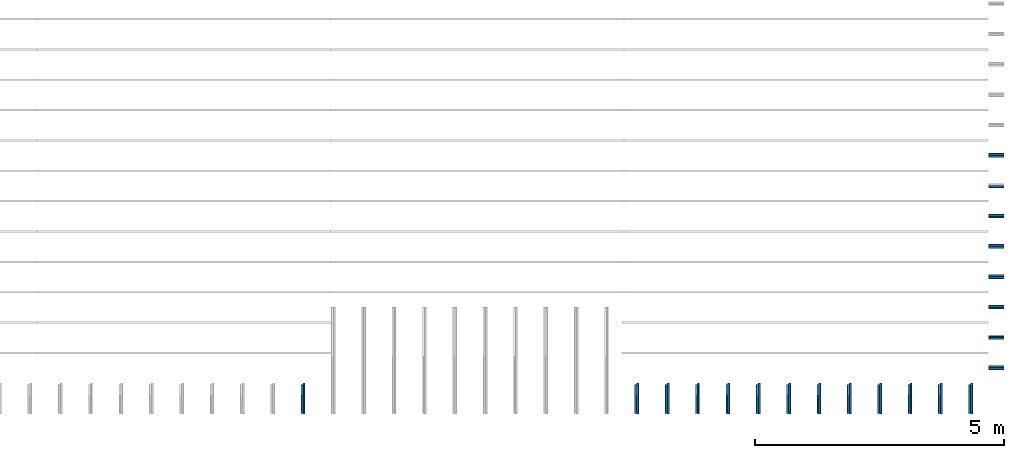
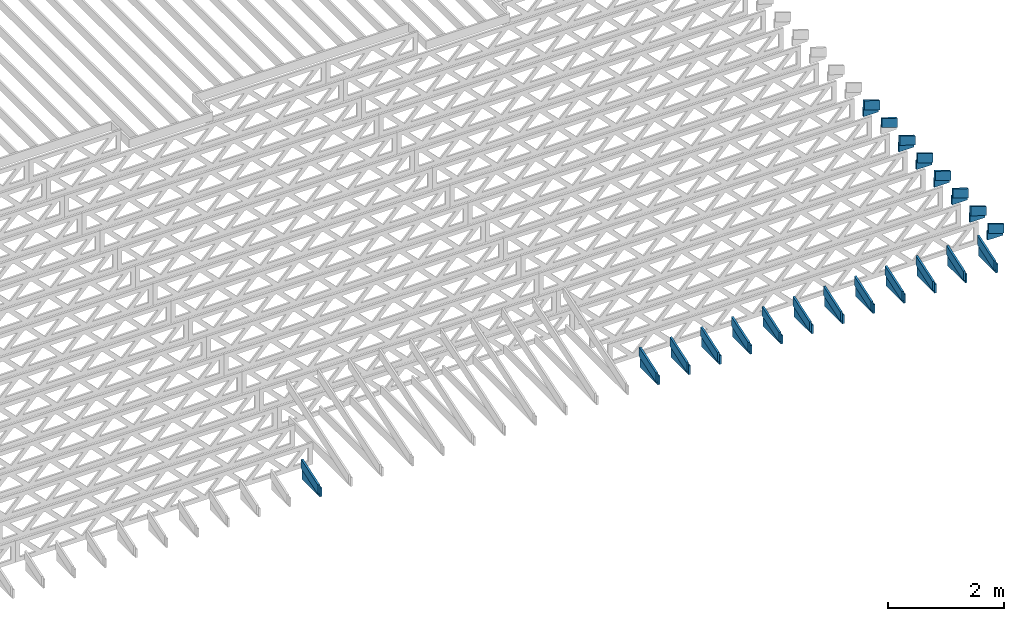
# One storey, part 15 of 17: 41 beams, 4 elements without a shape of their own.
"""IFC4 building model written with IfcOpenShell, lengths in feet."""

from ifc_helpers import new_model, entity, si_unit, converted_unit, derived_unit, direction, frame, frame_2d, origin, origin_2d_with_axis, place, context, subcontext, project, spatial, rectangle, extrude, clip, halfspace, source, transform, mapped, material, material_profile, profile_set, profile_usage, type_object, type_shapes, element, aggregate, save


model = new_model("IFC4")

# Units and contexts
model_context = context("Model", 3, precision=0.0001, world=origin(), true_north=direction((6.12303176911189e-17, 1.0)))
body_context = subcontext(model_context, "Body", "Model", "MODEL_VIEW")
ifc_project = project(units=[converted_unit("LENGTHUNIT", "FOOT", entity("IfcRatioMeasure", 0.3048), si_unit("LENGTHUNIT", "METRE"), dimensions=[1, 0, 0, 0, 0, 0, 0]), converted_unit("AREAUNIT", "SQUARE FOOT", entity("IfcRatioMeasure", 0.09290304), si_unit("AREAUNIT", "SQUARE_METRE"), dimensions=[2, 0, 0, 0, 0, 0, 0]), converted_unit("VOLUMEUNIT", "CUBIC FOOT", entity("IfcRatioMeasure", 0.028316846592), si_unit("VOLUMEUNIT", "CUBIC_METRE"), dimensions=[3, 0, 0, 0, 0, 0, 0]), converted_unit("PLANEANGLEUNIT", "DEGREE", entity("IfcRatioMeasure", 0.0174532925199433), si_unit("PLANEANGLEUNIT", "RADIAN"), dimensions=[0, 0, 0, 0, 0, 0, 0]), si_unit("MASSUNIT", "GRAM", prefix="KILO"), derived_unit("MASSDENSITYUNIT", [(si_unit("MASSUNIT", "GRAM", prefix="KILO"), 1), (si_unit("LENGTHUNIT", "METRE"), -3)]), derived_unit("MOMENTOFINERTIAUNIT", [(si_unit("LENGTHUNIT", "METRE"), 4)]), si_unit("TIMEUNIT", "SECOND"), si_unit("FREQUENCYUNIT", "HERTZ"), si_unit("THERMODYNAMICTEMPERATUREUNIT", "DEGREE_CELSIUS"), derived_unit("THERMALTRANSMITTANCEUNIT", [(si_unit("MASSUNIT", "GRAM", prefix="KILO"), 1), (si_unit("THERMODYNAMICTEMPERATUREUNIT", "KELVIN"), -1), (si_unit("TIMEUNIT", "SECOND"), -3)]), derived_unit("VOLUMETRICFLOWRATEUNIT", [(si_unit("LENGTHUNIT", "METRE"), 3), (si_unit("TIMEUNIT", "SECOND"), -1)]), si_unit("ELECTRICCURRENTUNIT", "AMPERE"), si_unit("ELECTRICVOLTAGEUNIT", "VOLT"), si_unit("POWERUNIT", "WATT"), si_unit("FORCEUNIT", "NEWTON"), si_unit("ILLUMINANCEUNIT", "LUX"), si_unit("LUMINOUSFLUXUNIT", "LUMEN"), si_unit("LUMINOUSINTENSITYUNIT", "CANDELA"), derived_unit("USERDEFINED", [(si_unit("MASSUNIT", "GRAM", prefix="KILO"), -1), (si_unit("LENGTHUNIT", "METRE"), -2), (si_unit("TIMEUNIT", "SECOND"), 3), (si_unit("LUMINOUSFLUXUNIT", "LUMEN"), 1)]), derived_unit("LINEARVELOCITYUNIT", [(si_unit("LENGTHUNIT", "METRE"), 1), (si_unit("TIMEUNIT", "SECOND"), -1)]), si_unit("PRESSUREUNIT", "PASCAL"), derived_unit("USERDEFINED", [(si_unit("LENGTHUNIT", "METRE"), -2), (si_unit("MASSUNIT", "GRAM", prefix="KILO"), 1), (si_unit("TIMEUNIT", "SECOND"), -2)]), derived_unit("LINEARFORCEUNIT", [(si_unit("MASSUNIT", "GRAM", prefix="KILO"), 1), (si_unit("LENGTHUNIT", "METRE"), 1), (si_unit("TIMEUNIT", "SECOND"), -2), (si_unit("LENGTHUNIT", "METRE"), -1)]), derived_unit("PLANARFORCEUNIT", [(si_unit("MASSUNIT", "GRAM", prefix="KILO"), 1), (si_unit("LENGTHUNIT", "METRE"), 1), (si_unit("TIMEUNIT", "SECOND"), -2), (si_unit("LENGTHUNIT", "METRE"), -2)])], contexts=[model_context])

# Site, building, storey
site_placement = place(None, origin())
site = spatial("IfcSite", under=ifc_project, at=site_placement, CompositionType="ELEMENT")
building_placement = place(site_placement, origin())
building = spatial("IfcBuilding", under=site, at=building_placement, CompositionType="ELEMENT")
storey_placement = place(building_placement, frame((0.0, 0.0, 30.4375000000082)))
storey = spatial("IfcBuildingStorey", under=building, at=storey_placement, Name="ROOF", CompositionType="ELEMENT", Elevation=30.4375000000082)

# Assembly, beams
assembly_1_placement = place(storey_placement, origin())
assembly_1 = element("IfcElementAssembly", 1, at=assembly_1_placement, inside=storey, Name="Structural Beam System:Structural Framing System", ObjectType="Structural Beam System:Structural Framing System", AssemblyPlace="NOTDEFINED", PredefinedType="BEAM_GRID")
ifc_material_1 = material(Name="BOTTOM CHORD OF FIELD FRAMED OVERHANG", Category="Materials")
ifc_material_profile_1 = material_profile(ifc_material_1, rectangle(XDim=0.604166666666667, YDim=0.125000000000011, at=origin_2d_with_axis()), Name="2X8 - BOTTOM CHORD")
ifc_profile_set_1 = profile_set([ifc_material_profile_1], Name="2X8 - BOTTOM CHORD")
ifc_profile_usage_1 = profile_usage(ifc_profile_set_1, cardinal=8)
beam_type_1 = type_object("IfcBeamType", Name="061100 - Wood Framing:2X8 - BOTTOM CHORD", PredefinedType="BEAM", material=ifc_profile_set_1)
shared_shape_1 = source(origin(), body_context, "Body", "SweptSolid", [
    extrude(rectangle(XDim=0.604166666666667, YDim=0.125000000000011, at=origin_2d_with_axis()), frame((-1.0, 0.0, 0.0), z_axis=(1.0, 0.0, 0.0), x_axis=(0.0, 0.0, -1.0)), (0.0, 0.0, 1.0), 1.9999999999992),
])
type_shapes(beam_type_1, [shared_shape_1])
beam_1_placement = place(assembly_1_placement, frame((-141.488158437574, 922.861950355462, 1.07291666665406), z_axis=(0.0, 0.0, 1.0), x_axis=(0.0, -1.0, 0.0)))
beam_1 = element("IfcBeam", 2, at=beam_1_placement, type_object=beam_type_1, material=ifc_profile_usage_1, Name="061100 - Wood Framing:2X8 - BOTTOM CHORD", ObjectType="061100 - Wood Framing:2X8 - BOTTOM CHORD", PredefinedType="BEAM", context=body_context, shape_type="MappedRepresentation", body=[
    mapped(shared_shape_1, transform((0.0, 0.0, 0.0), scale=1.0)),
])
ifc_profile_usage_2 = profile_usage(ifc_profile_set_1, cardinal=8)
beam_2_placement = place(assembly_1_placement, frame((-143.488158437574, 922.861949852958, 1.07291666665406), z_axis=(0.0, 0.0, 1.0), x_axis=(0.0, -1.0, 0.0)))
beam_2 = element("IfcBeam", 3, at=beam_2_placement, type_object=beam_type_1, material=ifc_profile_usage_2, Name="061100 - Wood Framing:2X8 - BOTTOM CHORD", ObjectType="061100 - Wood Framing:2X8 - BOTTOM CHORD", PredefinedType="BEAM", context=body_context, shape_type="MappedRepresentation", body=[
    mapped(shared_shape_1, transform((0.0, 0.0, 0.0), scale=1.0)),
])
ifc_profile_usage_3 = profile_usage(ifc_profile_set_1, cardinal=8)
beam_3_placement = place(assembly_1_placement, frame((-145.488158437574, 922.861949350454, 1.07291666665406), z_axis=(0.0, 0.0, 1.0), x_axis=(0.0, -1.0, 0.0)))
beam_3 = element("IfcBeam", 4, at=beam_3_placement, type_object=beam_type_1, material=ifc_profile_usage_3, Name="061100 - Wood Framing:2X8 - BOTTOM CHORD", ObjectType="061100 - Wood Framing:2X8 - BOTTOM CHORD", PredefinedType="BEAM", context=body_context, shape_type="MappedRepresentation", body=[
    mapped(shared_shape_1, transform((0.0, 0.0, 0.0), scale=1.0)),
])
ifc_profile_usage_4 = profile_usage(ifc_profile_set_1, cardinal=8)
beam_4_placement = place(assembly_1_placement, frame((-147.488158437574, 922.86194884795, 1.07291666665406), z_axis=(0.0, 0.0, 1.0), x_axis=(0.0, -1.0, 0.0)))
beam_4 = element("IfcBeam", 5, at=beam_4_placement, type_object=beam_type_1, material=ifc_profile_usage_4, Name="061100 - Wood Framing:2X8 - BOTTOM CHORD", ObjectType="061100 - Wood Framing:2X8 - BOTTOM CHORD", PredefinedType="BEAM", context=body_context, shape_type="MappedRepresentation", body=[
    mapped(shared_shape_1, transform((0.0, 0.0, 0.0), scale=1.0)),
])
ifc_profile_usage_5 = profile_usage(ifc_profile_set_1, cardinal=8)
beam_5_placement = place(assembly_1_placement, frame((-149.488158437574, 922.861948345447, 1.07291666665406), z_axis=(0.0, 0.0, 1.0), x_axis=(0.0, -1.0, 0.0)))
beam_5 = element("IfcBeam", 6, at=beam_5_placement, type_object=beam_type_1, material=ifc_profile_usage_5, Name="061100 - Wood Framing:2X8 - BOTTOM CHORD", ObjectType="061100 - Wood Framing:2X8 - BOTTOM CHORD", PredefinedType="BEAM", context=body_context, shape_type="MappedRepresentation", body=[
    mapped(shared_shape_1, transform((0.0, 0.0, 0.0), scale=1.0)),
])
ifc_profile_usage_6 = profile_usage(ifc_profile_set_1, cardinal=8)
beam_6_placement = place(assembly_1_placement, frame((-151.488158437574, 922.861947842943, 1.07291666665406), z_axis=(0.0, 0.0, 1.0), x_axis=(0.0, -1.0, 0.0)))
beam_6 = element("IfcBeam", 7, at=beam_6_placement, type_object=beam_type_1, material=ifc_profile_usage_6, Name="061100 - Wood Framing:2X8 - BOTTOM CHORD", ObjectType="061100 - Wood Framing:2X8 - BOTTOM CHORD", PredefinedType="BEAM", context=body_context, shape_type="MappedRepresentation", body=[
    mapped(shared_shape_1, transform((0.0, 0.0, 0.0), scale=1.0)),
])
ifc_profile_usage_7 = profile_usage(ifc_profile_set_1, cardinal=8)
beam_7_placement = place(assembly_1_placement, frame((-153.488158437574, 922.861947340439, 1.07291666665406), z_axis=(0.0, 0.0, 1.0), x_axis=(0.0, -1.0, 0.0)))
beam_7 = element("IfcBeam", 8, at=beam_7_placement, type_object=beam_type_1, material=ifc_profile_usage_7, Name="061100 - Wood Framing:2X8 - BOTTOM CHORD", ObjectType="061100 - Wood Framing:2X8 - BOTTOM CHORD", PredefinedType="BEAM", context=body_context, shape_type="MappedRepresentation", body=[
    mapped(shared_shape_1, transform((0.0, 0.0, 0.0), scale=1.0)),
])
ifc_profile_usage_8 = profile_usage(ifc_profile_set_1, cardinal=8)
beam_8_placement = place(assembly_1_placement, frame((-155.488158437574, 922.861946837936, 1.07291666665406), z_axis=(0.0, 0.0, 1.0), x_axis=(0.0, -1.0, 0.0)))
beam_8 = element("IfcBeam", 9, at=beam_8_placement, type_object=beam_type_1, material=ifc_profile_usage_8, Name="061100 - Wood Framing:2X8 - BOTTOM CHORD", ObjectType="061100 - Wood Framing:2X8 - BOTTOM CHORD", PredefinedType="BEAM", context=body_context, shape_type="MappedRepresentation", body=[
    mapped(shared_shape_1, transform((0.0, 0.0, 0.0), scale=1.0)),
])
ifc_profile_usage_9 = profile_usage(ifc_profile_set_1, cardinal=8)
beam_9_placement = place(assembly_1_placement, frame((-157.488158437574, 922.861946335432, 1.07291666665406), z_axis=(0.0, 0.0, 1.0), x_axis=(0.0, -1.0, 0.0)))
beam_9 = element("IfcBeam", 10, at=beam_9_placement, type_object=beam_type_1, material=ifc_profile_usage_9, Name="061100 - Wood Framing:2X8 - BOTTOM CHORD", ObjectType="061100 - Wood Framing:2X8 - BOTTOM CHORD", PredefinedType="BEAM", context=body_context, shape_type="MappedRepresentation", body=[
    mapped(shared_shape_1, transform((0.0, 0.0, 0.0), scale=1.0)),
])
ifc_profile_usage_10 = profile_usage(ifc_profile_set_1, cardinal=8)
beam_10_placement = place(assembly_1_placement, frame((-159.488158437574, 922.861945832928, 1.07291666665406), z_axis=(0.0, 0.0, 1.0), x_axis=(0.0, -1.0, 0.0)))
beam_10 = element("IfcBeam", 11, at=beam_10_placement, type_object=beam_type_1, material=ifc_profile_usage_10, Name="061100 - Wood Framing:2X8 - BOTTOM CHORD", ObjectType="061100 - Wood Framing:2X8 - BOTTOM CHORD", PredefinedType="BEAM", context=body_context, shape_type="MappedRepresentation", body=[
    mapped(shared_shape_1, transform((0.0, 0.0, 0.0), scale=1.0)),
])
ifc_profile_usage_11 = profile_usage(ifc_profile_set_1, cardinal=8)
beam_11_placement = place(assembly_1_placement, frame((-161.488158437574, 922.861945330424, 1.07291666665406), z_axis=(0.0, 0.0, 1.0), x_axis=(0.0, -1.0, 0.0)))
beam_11 = element("IfcBeam", 12, at=beam_11_placement, type_object=beam_type_1, material=ifc_profile_usage_11, Name="061100 - Wood Framing:2X8 - BOTTOM CHORD", ObjectType="061100 - Wood Framing:2X8 - BOTTOM CHORD", PredefinedType="BEAM", context=body_context, shape_type="MappedRepresentation", body=[
    mapped(shared_shape_1, transform((0.0, 0.0, 0.0), scale=1.0)),
])
ifc_profile_usage_12 = profile_usage(ifc_profile_set_1, cardinal=8)
beam_12_placement = place(assembly_1_placement, frame((-163.488158437574, 922.861944827921, 1.07291666665406), z_axis=(0.0, 0.0, 1.0), x_axis=(0.0, -1.0, 0.0)))
beam_12 = element("IfcBeam", 13, at=beam_12_placement, type_object=beam_type_1, material=ifc_profile_usage_12, Name="061100 - Wood Framing:2X8 - BOTTOM CHORD", ObjectType="061100 - Wood Framing:2X8 - BOTTOM CHORD", PredefinedType="BEAM", context=body_context, shape_type="MappedRepresentation", body=[
    mapped(shared_shape_1, transform((0.0, 0.0, 0.0), scale=1.0)),
])
ifc_profile_usage_13 = profile_usage(ifc_profile_set_1, cardinal=8)
beam_13_placement = place(assembly_1_placement, frame((-185.488158437574, 922.86193930038, 1.07291666665406), z_axis=(0.0, 0.0, 1.0), x_axis=(0.0, -1.0, 0.0)))
beam_13 = element("IfcBeam", 14, at=beam_13_placement, type_object=beam_type_1, material=ifc_profile_usage_13, Name="061100 - Wood Framing:2X8 - BOTTOM CHORD", ObjectType="061100 - Wood Framing:2X8 - BOTTOM CHORD", PredefinedType="BEAM", context=body_context, shape_type="MappedRepresentation", body=[
    mapped(shared_shape_1, transform((0.0, 0.0, 0.0), scale=1.0)),
])
aggregate(assembly_1, [beam_1, beam_2, beam_3, beam_4, beam_5, beam_6, beam_7, beam_8, beam_9, beam_10, beam_11, beam_12, beam_13])

assembly_2_placement = place(storey_placement, origin())
assembly_2 = element("IfcElementAssembly", 15, at=assembly_2_placement, inside=storey, Name="Structural Beam System:Structural Framing System", ObjectType="Structural Beam System:Structural Framing System", AssemblyPlace="NOTDEFINED", PredefinedType="BEAM_GRID")
ifc_material_2 = material(Name="TOP CHORD OF FIELD FRAMED OVERHANG", Category="Materials")
ifc_material_profile_2 = material_profile(ifc_material_2, rectangle(XDim=0.604166666666667, YDim=0.125, at=origin_2d_with_axis()), Name="2X8 TOP CHORD")
ifc_profile_set_2 = profile_set([ifc_material_profile_2], Name="2X8 TOP CHORD")
ifc_profile_usage_14 = profile_usage(ifc_profile_set_2, cardinal=8)
beam_type_2 = type_object("IfcBeamType", Name="Dimension Lumber - Ends:2X8 TOP CHORD", PredefinedType="BEAM", material=ifc_profile_set_2)
shared_shape_2 = source(origin(), body_context, "Body", "Clipping", [
    clip(clip(extrude(rectangle(XDim=0.604166666666667, YDim=0.125, at=origin_2d_with_axis()), frame((-0.999187080503646, 0.0, 0.0), z_axis=(1.0, 0.0, 0.0), x_axis=(0.0, 0.0, -1.0)), (0.0, 0.0, 1.0), 2.19970506951975), halfspace(frame((0.999187080503609, -0.0625000000000025, -0.302083333333339), z_axis=(0.948710608132914, 0.0, -0.316145823973805), x_axis=(0.0, 1.0, 0.0)), False)), halfspace(frame((-0.797856171991158, -0.0625000000000025, 0.302083333333328), z_axis=(-0.948710608132914, 0.0, 0.316145823973806), x_axis=(0.0, 1.0, 0.0)), False)),
])
type_shapes(beam_type_2, [shared_shape_2])
beam_14_placement = place(assembly_2_placement, frame((-141.613159217447, 922.714304085524, 1.58619153801152), z_axis=(0.0, -0.316227766016851, 0.94868329805051), x_axis=(0.0, 0.94868329805051, 0.316227766016851)))
beam_14 = element("IfcBeam", 16, at=beam_14_placement, type_object=beam_type_2, material=ifc_profile_usage_14, Name="Dimension Lumber - Ends:2X8 TOP CHORD", ObjectType="Dimension Lumber - Ends:2X8 TOP CHORD", PredefinedType="BEAM", context=body_context, shape_type="MappedRepresentation", body=[
    mapped(shared_shape_2, transform((0.0, 0.0, 0.0), scale=1.0)),
])
ifc_profile_usage_15 = profile_usage(ifc_profile_set_2, cardinal=8)
beam_15_placement = place(assembly_2_placement, frame((-143.613159217447, 922.714304085524, 1.58619153801158), z_axis=(0.0, -0.316227766016852, 0.948683298050509), x_axis=(0.0, 0.948683298050509, 0.316227766016852)))
beam_15 = element("IfcBeam", 17, at=beam_15_placement, type_object=beam_type_2, material=ifc_profile_usage_15, Name="Dimension Lumber - Ends:2X8 TOP CHORD", ObjectType="Dimension Lumber - Ends:2X8 TOP CHORD", PredefinedType="BEAM", context=body_context, shape_type="MappedRepresentation", body=[
    mapped(shared_shape_2, transform((0.0, 0.0, 0.0), scale=1.0)),
])
ifc_profile_usage_16 = profile_usage(ifc_profile_set_2, cardinal=8)
beam_16_placement = place(assembly_2_placement, frame((-145.613159217447, 922.714304085524, 1.58619153801152), z_axis=(0.0, -0.316227766016851, 0.94868329805051), x_axis=(0.0, 0.94868329805051, 0.316227766016851)))
beam_16 = element("IfcBeam", 18, at=beam_16_placement, type_object=beam_type_2, material=ifc_profile_usage_16, Name="Dimension Lumber - Ends:2X8 TOP CHORD", ObjectType="Dimension Lumber - Ends:2X8 TOP CHORD", PredefinedType="BEAM", context=body_context, shape_type="MappedRepresentation", body=[
    mapped(shared_shape_2, transform((0.0, 0.0, 0.0), scale=1.0)),
])
ifc_profile_usage_17 = profile_usage(ifc_profile_set_2, cardinal=8)
beam_17_placement = place(assembly_2_placement, frame((-147.613159217447, 922.714304085524, 1.58619153801152), z_axis=(0.0, -0.316227766016851, 0.94868329805051), x_axis=(0.0, 0.94868329805051, 0.316227766016851)))
beam_17 = element("IfcBeam", 19, at=beam_17_placement, type_object=beam_type_2, material=ifc_profile_usage_17, Name="Dimension Lumber - Ends:2X8 TOP CHORD", ObjectType="Dimension Lumber - Ends:2X8 TOP CHORD", PredefinedType="BEAM", context=body_context, shape_type="MappedRepresentation", body=[
    mapped(shared_shape_2, transform((0.0, 0.0, 0.0), scale=1.0)),
])
ifc_profile_usage_18 = profile_usage(ifc_profile_set_2, cardinal=8)
beam_18_placement = place(assembly_2_placement, frame((-149.613159217447, 922.714304085524, 1.58619153801158), z_axis=(0.0, -0.316227766016849, 0.94868329805051), x_axis=(0.0, 0.94868329805051, 0.316227766016849)))
beam_18 = element("IfcBeam", 20, at=beam_18_placement, type_object=beam_type_2, material=ifc_profile_usage_18, Name="Dimension Lumber - Ends:2X8 TOP CHORD", ObjectType="Dimension Lumber - Ends:2X8 TOP CHORD", PredefinedType="BEAM", context=body_context, shape_type="MappedRepresentation", body=[
    mapped(shared_shape_2, transform((0.0, 0.0, 0.0), scale=1.0)),
])
ifc_profile_usage_19 = profile_usage(ifc_profile_set_2, cardinal=8)
beam_19_placement = place(assembly_2_placement, frame((-151.613159217447, 922.714304085524, 1.58619153801158), z_axis=(0.0, -0.316227766016849, 0.94868329805051), x_axis=(0.0, 0.94868329805051, 0.316227766016849)))
beam_19 = element("IfcBeam", 21, at=beam_19_placement, type_object=beam_type_2, material=ifc_profile_usage_19, Name="Dimension Lumber - Ends:2X8 TOP CHORD", ObjectType="Dimension Lumber - Ends:2X8 TOP CHORD", PredefinedType="BEAM", context=body_context, shape_type="MappedRepresentation", body=[
    mapped(shared_shape_2, transform((0.0, 0.0, 0.0), scale=1.0)),
])
ifc_profile_usage_20 = profile_usage(ifc_profile_set_2, cardinal=8)
beam_20_placement = place(assembly_2_placement, frame((-153.613159217447, 922.714304085524, 1.58619153801158), z_axis=(0.0, -0.316227766016849, 0.94868329805051), x_axis=(0.0, 0.94868329805051, 0.316227766016849)))
beam_20 = element("IfcBeam", 22, at=beam_20_placement, type_object=beam_type_2, material=ifc_profile_usage_20, Name="Dimension Lumber - Ends:2X8 TOP CHORD", ObjectType="Dimension Lumber - Ends:2X8 TOP CHORD", PredefinedType="BEAM", context=body_context, shape_type="MappedRepresentation", body=[
    mapped(shared_shape_2, transform((0.0, 0.0, 0.0), scale=1.0)),
])
ifc_profile_usage_21 = profile_usage(ifc_profile_set_2, cardinal=8)
beam_21_placement = place(assembly_2_placement, frame((-155.613159217447, 922.714304085524, 1.58619153801158), z_axis=(0.0, -0.316227766016848, 0.948683298050511), x_axis=(0.0, 0.948683298050511, 0.316227766016848)))
beam_21 = element("IfcBeam", 23, at=beam_21_placement, type_object=beam_type_2, material=ifc_profile_usage_21, Name="Dimension Lumber - Ends:2X8 TOP CHORD", ObjectType="Dimension Lumber - Ends:2X8 TOP CHORD", PredefinedType="BEAM", context=body_context, shape_type="MappedRepresentation", body=[
    mapped(shared_shape_2, transform((0.0, 0.0, 0.0), scale=1.0)),
])
ifc_profile_usage_22 = profile_usage(ifc_profile_set_2, cardinal=8)
beam_22_placement = place(assembly_2_placement, frame((-157.613159217447, 922.714304085524, 1.58619153801158), z_axis=(0.0, -0.316227766016848, 0.948683298050511), x_axis=(0.0, 0.948683298050511, 0.316227766016848)))
beam_22 = element("IfcBeam", 24, at=beam_22_placement, type_object=beam_type_2, material=ifc_profile_usage_22, Name="Dimension Lumber - Ends:2X8 TOP CHORD", ObjectType="Dimension Lumber - Ends:2X8 TOP CHORD", PredefinedType="BEAM", context=body_context, shape_type="MappedRepresentation", body=[
    mapped(shared_shape_2, transform((0.0, 0.0, 0.0), scale=1.0)),
])
ifc_profile_usage_23 = profile_usage(ifc_profile_set_2, cardinal=8)
beam_23_placement = place(assembly_2_placement, frame((-159.613159217447, 922.714304085524, 1.58619153801158), z_axis=(0.0, -0.316227766016849, 0.94868329805051), x_axis=(0.0, 0.94868329805051, 0.316227766016849)))
beam_23 = element("IfcBeam", 25, at=beam_23_placement, type_object=beam_type_2, material=ifc_profile_usage_23, Name="Dimension Lumber - Ends:2X8 TOP CHORD", ObjectType="Dimension Lumber - Ends:2X8 TOP CHORD", PredefinedType="BEAM", context=body_context, shape_type="MappedRepresentation", body=[
    mapped(shared_shape_2, transform((0.0, 0.0, 0.0), scale=1.0)),
])
ifc_profile_usage_24 = profile_usage(ifc_profile_set_2, cardinal=8)
beam_24_placement = place(assembly_2_placement, frame((-161.613159217447, 922.714304085524, 1.58619153801158), z_axis=(0.0, -0.316227766016848, 0.948683298050511), x_axis=(0.0, 0.948683298050511, 0.316227766016848)))
beam_24 = element("IfcBeam", 26, at=beam_24_placement, type_object=beam_type_2, material=ifc_profile_usage_24, Name="Dimension Lumber - Ends:2X8 TOP CHORD", ObjectType="Dimension Lumber - Ends:2X8 TOP CHORD", PredefinedType="BEAM", context=body_context, shape_type="MappedRepresentation", body=[
    mapped(shared_shape_2, transform((0.0, 0.0, 0.0), scale=1.0)),
])
ifc_profile_usage_25 = profile_usage(ifc_profile_set_2, cardinal=8)
beam_25_placement = place(assembly_2_placement, frame((-163.613159217447, 922.714304085524, 1.58619153801158), z_axis=(0.0, -0.316227766016848, 0.948683298050511), x_axis=(0.0, 0.948683298050511, 0.316227766016848)))
beam_25 = element("IfcBeam", 27, at=beam_25_placement, type_object=beam_type_2, material=ifc_profile_usage_25, Name="Dimension Lumber - Ends:2X8 TOP CHORD", ObjectType="Dimension Lumber - Ends:2X8 TOP CHORD", PredefinedType="BEAM", context=body_context, shape_type="MappedRepresentation", body=[
    mapped(shared_shape_2, transform((0.0, 0.0, 0.0), scale=1.0)),
])
ifc_profile_usage_26 = profile_usage(ifc_profile_set_2, cardinal=8)
beam_26_placement = place(assembly_2_placement, frame((-185.613159217448, 922.714304085524, 1.58619153801163), z_axis=(0.0, -0.31622776601686, 0.948683298050507), x_axis=(0.0, 0.948683298050507, 0.31622776601686)))
beam_26 = element("IfcBeam", 28, at=beam_26_placement, type_object=beam_type_2, material=ifc_profile_usage_26, Name="Dimension Lumber - Ends:2X8 TOP CHORD", ObjectType="Dimension Lumber - Ends:2X8 TOP CHORD", PredefinedType="BEAM", context=body_context, shape_type="MappedRepresentation", body=[
    mapped(shared_shape_2, transform((0.0, 0.0, 0.0), scale=1.0)),
])
aggregate(assembly_2, [beam_14, beam_15, beam_16, beam_17, beam_18, beam_19, beam_20, beam_21, beam_22, beam_23, beam_24, beam_25, beam_26])

assembly_3_placement = place(storey_placement, origin())
assembly_3 = element("IfcElementAssembly", 29, at=assembly_3_placement, inside=storey, Name="Structural Beam System:Structural Framing System", ObjectType="Structural Beam System:Structural Framing System", AssemblyPlace="NOTDEFINED", PredefinedType="BEAM_GRID")
ifc_profile_usage_27 = profile_usage(ifc_profile_set_2, cardinal=8)
beam_type_3 = type_object("IfcBeamType", Name="Dimension Lumber - Ends:2X8 TOP CHORD", PredefinedType="BEAM", material=ifc_profile_set_2)
shared_shape_3 = source(origin(), body_context, "Body", "Clipping", [
    clip(clip(extrude(rectangle(XDim=0.604166666666671, YDim=0.125, at=frame_2d((-1.52655665885959e-15, 0.0), x_axis=(1.0, 0.0))), frame((-0.529560098375526, 0.0, 0.0), z_axis=(1.0, 0.0, 0.0), x_axis=(0.0, 0.0, -1.0)), (0.0, 0.0, 1.0), 1.26045110526351), halfspace(frame((0.529560098375489, -0.0625000000000025, -0.302083333333339), z_axis=(0.948710608132914, 0.0, -0.316145823973805), x_axis=(0.0, 1.0, 0.0)), False)), halfspace(frame((-0.328229189863038, -0.0625000000000025, 0.302083333333328), z_axis=(-0.948710608132914, 0.0, 0.316145823973805), x_axis=(0.0, 1.0, 0.0)), False)),
])
type_shapes(beam_type_3, [shared_shape_3])
beam_27_placement = place(assembly_3_placement, frame((-139.765291953278, 938.820268401833, 1.43770432947406), z_axis=(0.316227766016842, 0.0, 0.948683298050513), x_axis=(-0.948683298050514, 0.0, 0.316227766016839)))
beam_27 = element("IfcBeam", 30, at=beam_27_placement, type_object=beam_type_3, material=ifc_profile_usage_27, Name="Dimension Lumber - Ends:2X8 TOP CHORD", ObjectType="Dimension Lumber - Ends:2X8 TOP CHORD", PredefinedType="BEAM", context=body_context, shape_type="MappedRepresentation", body=[
    mapped(shared_shape_3, transform((0.0, 0.0, 0.0), scale=1.0)),
])
ifc_profile_usage_28 = profile_usage(ifc_profile_set_2, cardinal=8)
beam_28_placement = place(assembly_3_placement, frame((-139.765291953278, 936.820268401833, 1.43770432947404), z_axis=(0.316227766016839, 0.0, 0.948683298050514), x_axis=(-0.948683298050515, 0.0, 0.316227766016836)))
beam_28 = element("IfcBeam", 31, at=beam_28_placement, type_object=beam_type_3, material=ifc_profile_usage_28, Name="Dimension Lumber - Ends:2X8 TOP CHORD", ObjectType="Dimension Lumber - Ends:2X8 TOP CHORD", PredefinedType="BEAM", context=body_context, shape_type="MappedRepresentation", body=[
    mapped(shared_shape_3, transform((0.0, 0.0, 0.0), scale=1.0)),
])
ifc_profile_usage_29 = profile_usage(ifc_profile_set_2, cardinal=8)
beam_29_placement = place(assembly_3_placement, frame((-139.765291953278, 934.820268401833, 1.43770432947402), z_axis=(0.316227766016842, 0.0, 0.948683298050513), x_axis=(-0.948683298050514, 0.0, 0.316227766016839)))
beam_29 = element("IfcBeam", 32, at=beam_29_placement, type_object=beam_type_3, material=ifc_profile_usage_29, Name="Dimension Lumber - Ends:2X8 TOP CHORD", ObjectType="Dimension Lumber - Ends:2X8 TOP CHORD", PredefinedType="BEAM", context=body_context, shape_type="MappedRepresentation", body=[
    mapped(shared_shape_3, transform((0.0, 0.0, 0.0), scale=1.0)),
])
ifc_profile_usage_30 = profile_usage(ifc_profile_set_2, cardinal=8)
beam_30_placement = place(assembly_3_placement, frame((-139.765291953278, 932.820268401833, 1.43770432947401), z_axis=(0.316227766016842, 0.0, 0.948683298050513), x_axis=(-0.948683298050514, 0.0, 0.316227766016839)))
beam_30 = element("IfcBeam", 33, at=beam_30_placement, type_object=beam_type_3, material=ifc_profile_usage_30, Name="Dimension Lumber - Ends:2X8 TOP CHORD", ObjectType="Dimension Lumber - Ends:2X8 TOP CHORD", PredefinedType="BEAM", context=body_context, shape_type="MappedRepresentation", body=[
    mapped(shared_shape_3, transform((0.0, 0.0, 0.0), scale=1.0)),
])
ifc_profile_usage_31 = profile_usage(ifc_profile_set_2, cardinal=8)
beam_31_placement = place(assembly_3_placement, frame((-139.765291953277, 930.820268401833, 1.43770432947471), z_axis=(0.316227766016833, 0.0, 0.948683298050516), x_axis=(-0.948683298050515, 0.0, 0.316227766016836)))
beam_31 = element("IfcBeam", 34, at=beam_31_placement, type_object=beam_type_3, material=ifc_profile_usage_31, Name="Dimension Lumber - Ends:2X8 TOP CHORD", ObjectType="Dimension Lumber - Ends:2X8 TOP CHORD", PredefinedType="BEAM", context=body_context, shape_type="MappedRepresentation", body=[
    mapped(shared_shape_3, transform((0.0, 0.0, 0.0), scale=1.0)),
])
ifc_profile_usage_32 = profile_usage(ifc_profile_set_2, cardinal=8)
beam_32_placement = place(assembly_3_placement, frame((-139.765291953278, 928.820268401833, 1.43770432947397), z_axis=(0.316227766016836, 0.0, 0.948683298050515), x_axis=(-0.948683298050516, 0.0, 0.316227766016833)))
beam_32 = element("IfcBeam", 35, at=beam_32_placement, type_object=beam_type_3, material=ifc_profile_usage_32, Name="Dimension Lumber - Ends:2X8 TOP CHORD", ObjectType="Dimension Lumber - Ends:2X8 TOP CHORD", PredefinedType="BEAM", context=body_context, shape_type="MappedRepresentation", body=[
    mapped(shared_shape_3, transform((0.0, 0.0, 0.0), scale=1.0)),
])
ifc_profile_usage_33 = profile_usage(ifc_profile_set_2, cardinal=8)
beam_33_placement = place(assembly_3_placement, frame((-139.765291953278, 926.820268401833, 1.43770432947396), z_axis=(0.316227766016839, 0.0, 0.948683298050514), x_axis=(-0.948683298050515, 0.0, 0.316227766016836)))
beam_33 = element("IfcBeam", 36, at=beam_33_placement, type_object=beam_type_3, material=ifc_profile_usage_33, Name="Dimension Lumber - Ends:2X8 TOP CHORD", ObjectType="Dimension Lumber - Ends:2X8 TOP CHORD", PredefinedType="BEAM", context=body_context, shape_type="MappedRepresentation", body=[
    mapped(shared_shape_3, transform((0.0, 0.0, 0.0), scale=1.0)),
])
ifc_profile_usage_34 = profile_usage(ifc_profile_set_2, cardinal=8)
beam_34_placement = place(assembly_3_placement, frame((-139.765291953278, 924.820268401833, 1.43770432947392), z_axis=(0.316227766016836, 0.0, 0.948683298050515), x_axis=(-0.948683298050516, 0.0, 0.316227766016833)))
beam_34 = element("IfcBeam", 37, at=beam_34_placement, type_object=beam_type_3, material=ifc_profile_usage_34, Name="Dimension Lumber - Ends:2X8 TOP CHORD", ObjectType="Dimension Lumber - Ends:2X8 TOP CHORD", PredefinedType="BEAM", context=body_context, shape_type="MappedRepresentation", body=[
    mapped(shared_shape_3, transform((0.0, 0.0, 0.0), scale=1.0)),
])
aggregate(assembly_3, [beam_27, beam_28, beam_29, beam_30, beam_31, beam_32, beam_33, beam_34])

assembly_4_placement = place(storey_placement, origin())
assembly_4 = element("IfcElementAssembly", 38, at=assembly_4_placement, inside=storey, Name="Structural Beam System:Structural Framing System", ObjectType="Structural Beam System:Structural Framing System", AssemblyPlace="NOTDEFINED", PredefinedType="BEAM_GRID")
ifc_profile_usage_35 = profile_usage(ifc_profile_set_1, cardinal=8)
beam_type_4 = type_object("IfcBeamType", Name="061100 - Wood Framing:2X8 - BOTTOM CHORD", PredefinedType="BEAM", material=ifc_profile_set_1)
shared_shape_4 = source(origin(), body_context, "Body", "SweptSolid", [
    extrude(rectangle(XDim=0.604166666666667, YDim=0.125000000000011, at=origin_2d_with_axis()), frame((-0.497179684451055, 0.0, 0.0), z_axis=(1.0, 0.0, 0.0), x_axis=(0.0, 0.0, -1.0)), (0.0, 0.0, 1.0), 0.99435936890211),
])
type_shapes(beam_type_4, [shared_shape_4])
beam_35_placement = place(assembly_4_placement, frame((-139.855564134411, 938.945268401832, 1.07291666665407)))
beam_35 = element("IfcBeam", 39, at=beam_35_placement, type_object=beam_type_4, material=ifc_profile_usage_35, Name="061100 - Wood Framing:2X8 - BOTTOM CHORD", ObjectType="061100 - Wood Framing:2X8 - BOTTOM CHORD", PredefinedType="BEAM", context=body_context, shape_type="MappedRepresentation", body=[
    mapped(shared_shape_4, transform((0.0, 0.0, 0.0), scale=1.0)),
])
ifc_profile_usage_36 = profile_usage(ifc_profile_set_1, cardinal=8)
beam_36_placement = place(assembly_4_placement, frame((-139.855564134411, 934.945268401832, 1.07291666665407)))
beam_36 = element("IfcBeam", 40, at=beam_36_placement, type_object=beam_type_4, material=ifc_profile_usage_36, Name="061100 - Wood Framing:2X8 - BOTTOM CHORD", ObjectType="061100 - Wood Framing:2X8 - BOTTOM CHORD", PredefinedType="BEAM", context=body_context, shape_type="MappedRepresentation", body=[
    mapped(shared_shape_4, transform((0.0, 0.0, 0.0), scale=1.0)),
])
ifc_profile_usage_37 = profile_usage(ifc_profile_set_1, cardinal=8)
beam_37_placement = place(assembly_4_placement, frame((-139.855564134411, 932.945268401832, 1.07291666665407)))
beam_37 = element("IfcBeam", 41, at=beam_37_placement, type_object=beam_type_4, material=ifc_profile_usage_37, Name="061100 - Wood Framing:2X8 - BOTTOM CHORD", ObjectType="061100 - Wood Framing:2X8 - BOTTOM CHORD", PredefinedType="BEAM", context=body_context, shape_type="MappedRepresentation", body=[
    mapped(shared_shape_4, transform((0.0, 0.0, 0.0), scale=1.0)),
])
ifc_profile_usage_38 = profile_usage(ifc_profile_set_1, cardinal=8)
beam_38_placement = place(assembly_4_placement, frame((-139.855564134411, 930.945268401832, 1.07291666665407)))
beam_38 = element("IfcBeam", 42, at=beam_38_placement, type_object=beam_type_4, material=ifc_profile_usage_38, Name="061100 - Wood Framing:2X8 - BOTTOM CHORD", ObjectType="061100 - Wood Framing:2X8 - BOTTOM CHORD", PredefinedType="BEAM", context=body_context, shape_type="MappedRepresentation", body=[
    mapped(shared_shape_4, transform((0.0, 0.0, 0.0), scale=1.0)),
])
ifc_profile_usage_39 = profile_usage(ifc_profile_set_1, cardinal=8)
beam_39_placement = place(assembly_4_placement, frame((-139.855564134411, 928.945268401832, 1.07291666665407)))
beam_39 = element("IfcBeam", 43, at=beam_39_placement, type_object=beam_type_4, material=ifc_profile_usage_39, Name="061100 - Wood Framing:2X8 - BOTTOM CHORD", ObjectType="061100 - Wood Framing:2X8 - BOTTOM CHORD", PredefinedType="BEAM", context=body_context, shape_type="MappedRepresentation", body=[
    mapped(shared_shape_4, transform((0.0, 0.0, 0.0), scale=1.0)),
])
ifc_profile_usage_40 = profile_usage(ifc_profile_set_1, cardinal=8)
beam_40_placement = place(assembly_4_placement, frame((-139.855564134411, 926.945268401832, 1.07291666665407)))
beam_40 = element("IfcBeam", 44, at=beam_40_placement, type_object=beam_type_4, material=ifc_profile_usage_40, Name="061100 - Wood Framing:2X8 - BOTTOM CHORD", ObjectType="061100 - Wood Framing:2X8 - BOTTOM CHORD", PredefinedType="BEAM", context=body_context, shape_type="MappedRepresentation", body=[
    mapped(shared_shape_4, transform((0.0, 0.0, 0.0), scale=1.0)),
])
ifc_profile_usage_41 = profile_usage(ifc_profile_set_1, cardinal=8)
beam_41_placement = place(assembly_4_placement, frame((-139.855564134411, 924.945268401832, 1.07291666665407)))
beam_41 = element("IfcBeam", 45, at=beam_41_placement, type_object=beam_type_4, material=ifc_profile_usage_41, Name="061100 - Wood Framing:2X8 - BOTTOM CHORD", ObjectType="061100 - Wood Framing:2X8 - BOTTOM CHORD", PredefinedType="BEAM", context=body_context, shape_type="MappedRepresentation", body=[
    mapped(shared_shape_4, transform((0.0, 0.0, 0.0), scale=1.0)),
])
aggregate(assembly_4, [beam_35, beam_36, beam_37, beam_38, beam_39, beam_40, beam_41])

save(model, "model.ifc")
